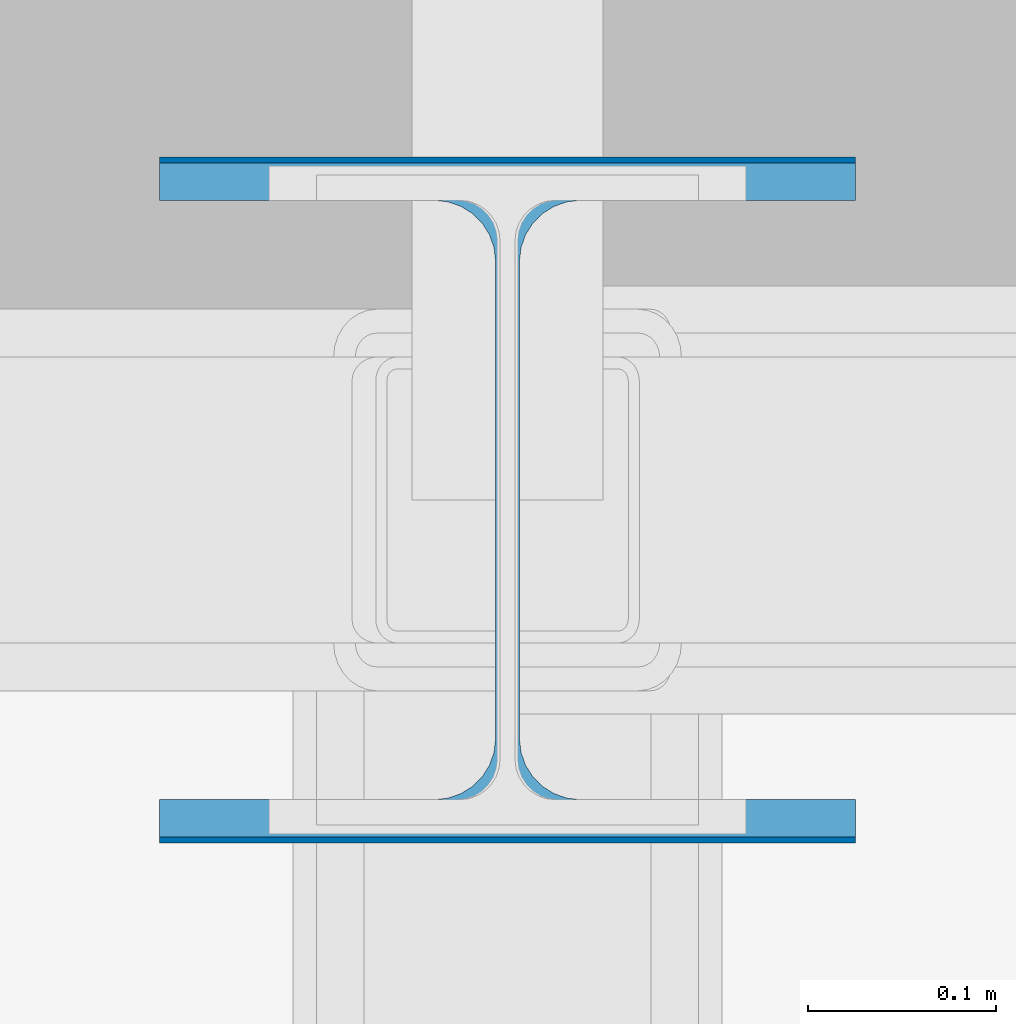
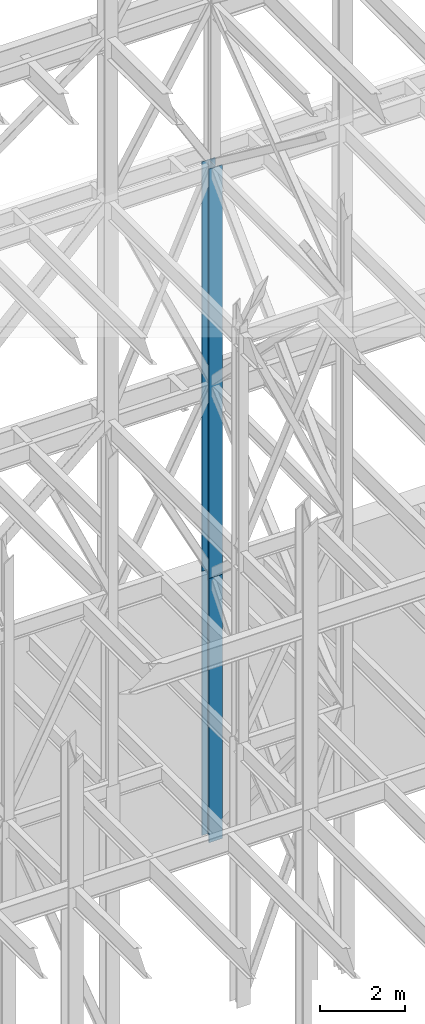
# One storey, part 99 of 150: 2 columns.
"""IFC2X3 building model written with IfcOpenShell, lengths in millimetres."""

from ifc_helpers import new_model, si_unit, frame, origin_with_axes, origin_2d_with_axis, place, context, subcontext, project, spatial, i_section, extrude, material, type_object, element, save


model = new_model("IFC2X3")

# Units and contexts
model_context = context("Model", 3, precision=1e-05, world=origin_with_axes())
body_context = subcontext(model_context, "Body", "Model", "MODEL_VIEW")
ifc_project = project(units=[si_unit("LENGTHUNIT", "METRE", prefix="MILLI"), si_unit("AREAUNIT", "SQUARE_METRE"), si_unit("VOLUMEUNIT", "CUBIC_METRE"), si_unit("MASSUNIT", "GRAM", prefix="KILO"), si_unit("TIMEUNIT", "SECOND"), si_unit("PLANEANGLEUNIT", "RADIAN"), si_unit("SOLIDANGLEUNIT", "STERADIAN"), si_unit("THERMODYNAMICTEMPERATUREUNIT", "DEGREE_CELSIUS"), si_unit("LUMINOUSINTENSITYUNIT", "LUMEN")], contexts=[model_context])

# Site, building, storey
site_placement = place(None, origin_with_axes())
site = spatial("IfcSite", under=ifc_project, at=site_placement, CompositionType="ELEMENT")
building_placement = place(site_placement, origin_with_axes())
building = spatial("IfcBuilding", under=site, at=building_placement, Name="Undefined", CompositionType="ELEMENT")
storey_placement = place(building_placement, origin_with_axes())
storey = spatial("IfcBuildingStorey", under=building, at=storey_placement, Name="Undefined", CompositionType="ELEMENT", Elevation=0.0)

# Columns
ifc_material = material(Name="STEEL/A992")
column_type_1 = type_object("IfcColumnType", Name="W14X99", PredefinedType="NOTDEFINED")
column_1_placement = place(storey_placement, frame((65836.8, 31877.0, 23774.401143), z_axis=(0.0, 0.0, 1.0), x_axis=(1.0, 0.0, 0.0)))
element("IfcColumn", 1, at=column_1_placement, inside=storey, type_object=column_type_1, material=ifc_material, Name="COLUMN", ObjectType="W14X99", context=body_context, shape_type="SweptSolid", body=[
    extrude(i_section(OverallWidth=370.84, OverallDepth=358.775, WebThickness=12.6999, FlangeThickness=19.812, FilletRadius=32.5755, at=origin_2d_with_axis()), frame((0.0, 0.0, 11811.0), z_axis=(0.0, 0.0, -1.0), x_axis=(-1.0, 0.0, 0.0)), (0.0, 0.0, 1.0), 11811.0),
])
column_type_2 = type_object("IfcColumnType", Name="W14X109", PredefinedType="NOTDEFINED")
column_2_placement = place(storey_placement, frame((65836.8, 31877.0, 16154.401143), z_axis=(0.0, 0.0, 1.0), x_axis=(1.0, 0.0, 0.0)))
element("IfcColumn", 2, at=column_2_placement, inside=storey, type_object=column_type_2, material=ifc_material, Name="COLUMN", ObjectType="W14X109", context=body_context, shape_type="SweptSolid", body=[
    extrude(i_section(OverallWidth=370.84, OverallDepth=365.125, WebThickness=12.6999, FlangeThickness=21.844, FilletRadius=33.7184, at=origin_2d_with_axis()), frame((0.0, 0.0, 7620.0), z_axis=(0.0, 0.0, -1.0), x_axis=(-1.0, 0.0, 0.0)), (0.0, 0.0, 1.0), 7620.0),
])

save(model, "model.ifc")
